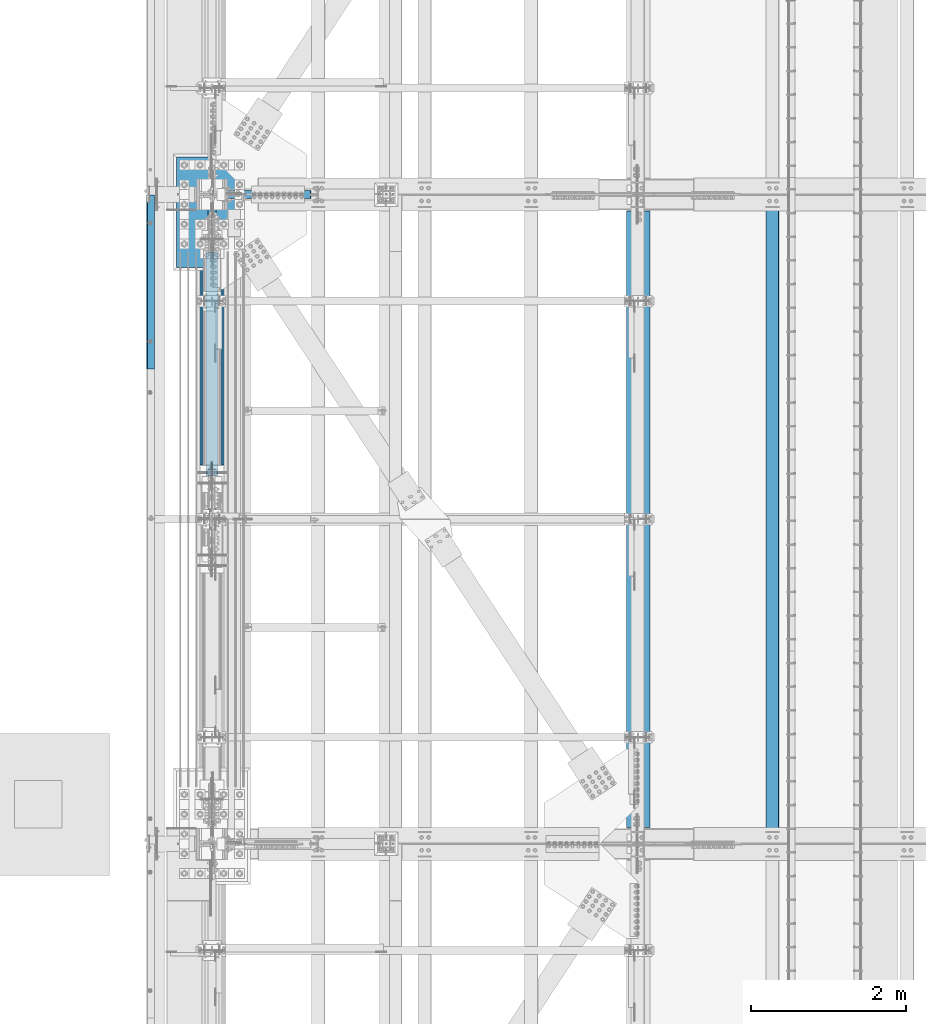
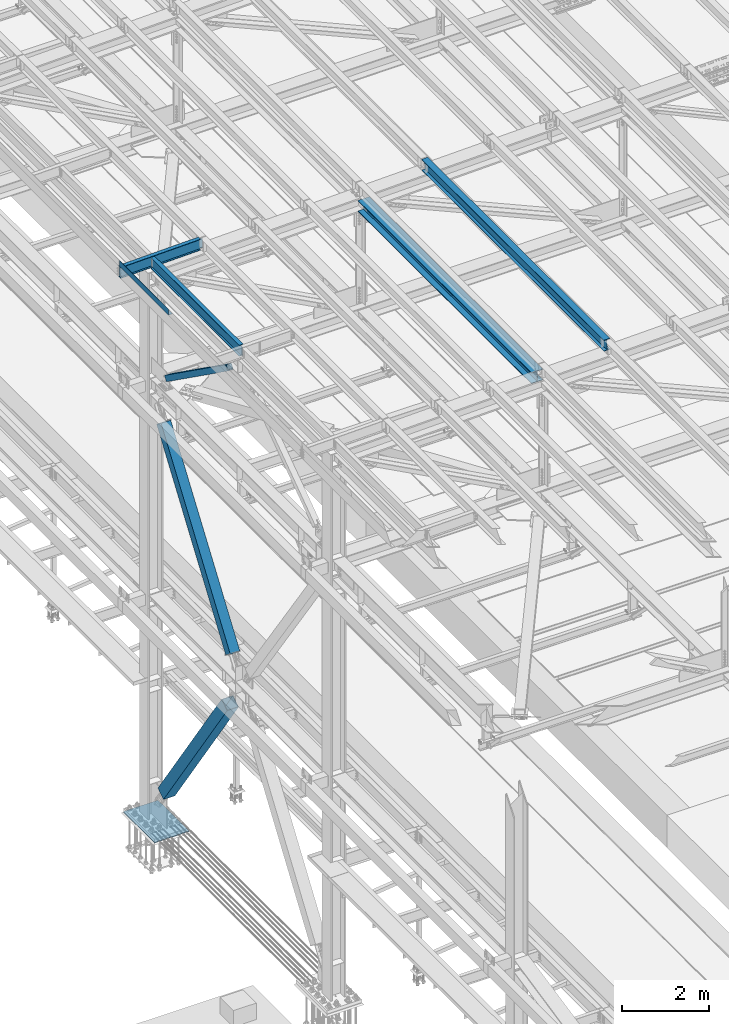
# One storey, part 1817 of 3843: 6 beams, 3 members, 9 elements without a shape of their own.
"""IFC2X3 building model written with IfcOpenShell, lengths in millimetres."""

from ifc_helpers import new_model, si_unit, frame, origin_with_axes, place, context, subcontext, project, spatial, faceted_brep, material, type_object, element, aggregate, save


model = new_model("IFC2X3")

# Units and contexts
model_context = context("Model", 3, precision=1e-05, world=origin_with_axes())
body_context = subcontext(model_context, "Body", "Model", "MODEL_VIEW")
ifc_project = project(units=[si_unit("LENGTHUNIT", "METRE", prefix="MILLI"), si_unit("AREAUNIT", "SQUARE_METRE"), si_unit("VOLUMEUNIT", "CUBIC_METRE"), si_unit("MASSUNIT", "GRAM", prefix="KILO"), si_unit("TIMEUNIT", "SECOND"), si_unit("PLANEANGLEUNIT", "RADIAN"), si_unit("SOLIDANGLEUNIT", "STERADIAN"), si_unit("THERMODYNAMICTEMPERATUREUNIT", "DEGREE_CELSIUS"), si_unit("LUMINOUSINTENSITYUNIT", "LUMEN")], contexts=[model_context])

# Site, building, storey
site_placement = place(None, origin_with_axes())
site = spatial("IfcSite", under=ifc_project, at=site_placement, CompositionType="ELEMENT")
building_placement = place(site_placement, origin_with_axes())
building = spatial("IfcBuilding", under=site, at=building_placement, Name="Undefined", CompositionType="ELEMENT")
storey_placement = place(building_placement, origin_with_axes())
storey = spatial("IfcBuildingStorey", under=building, at=storey_placement, Name="Undefined", CompositionType="ELEMENT", Elevation=0.0)

# Assembly, beam
assembly_1_placement = place(storey_placement, origin_with_axes())
assembly_1 = element("IfcElementAssembly", 1, at=assembly_1_placement, inside=storey, Name="BEAM", AssemblyPlace="NOTDEFINED", PredefinedType="RIGID_FRAME")
ifc_material_1 = material(Name="STEEL/A992")
beam_type_1 = type_object("IfcBeamType", Name="W12X26", PredefinedType="NOTDEFINED")
beam_1_placement = place(assembly_1_placement, frame((43792.6592622999, 50558.6833412205, 45765.7900980518), z_axis=(-0.0211520981284921, -0.000107078999957594, 0.999776263610439), x_axis=(-9.99999682051063e-10, 0.999999994264474, 0.000107103000027897)))
beam_1 = element("IfcBeam", 2, at=beam_1_placement, type_object=beam_type_1, material=ifc_material_1, Name="BEAM", ObjectType="W12X26", context=body_context, shape_type="Brep", body=[
    faceted_brep([(12.6997768804213, 82.5500000002576, -155.574999999757), (12.7008330253957, 82.5499999995081, -146.049999999814), (8343.90088084375, 82.5499999732128, -146.05000001478), (8343.89983598545, 82.549999998897, -155.574999980701), (12.7010127666945, 3.17499999966094, -146.04999999985), (8343.90106058505, 3.17499997337291, -146.050000014817), (12.7322905590408, 3.17500000024302, 146.049999999814), (8343.9323383774, 3.17499997394043, 146.049999984854), (12.7321108177493, 82.5500000000829, 146.049999999857), (8343.9321586361, 82.5499999737876, 146.049999984891), (12.7331307457644, 82.5500000001048, 155.574999999844), (8343.93317856411, 82.5499999738022, 155.574999984885), (12.7335046076623, -82.5499999995736, 155.574999999764), (8343.93355242601, -82.5500000258689, 155.574999984798), (12.7324846796473, -82.5499999995882, 146.049999999763), (8343.93253249799, -82.5500000258835, 146.049999984811), (12.7323049383558, -3.17499999974825, 146.049999999806), (8343.9323527567, -3.17500002604356, 146.049999984854), (12.7010271459949, -3.17500000032305, -146.049999999857), (8343.90107496434, -3.17500002661836, -146.050000014817), (12.7012068873009, -82.550000000163, -146.049999999894), (8343.90125470564, -82.5500000264656, -146.05000001486), (12.7002233139719, -82.5499999994645, -155.574999999291), (8343.90025833794, -82.5500000013853, -155.574999977143)], [[[0, 1, 2, 3]], [[1, 4, 5, 2]], [[4, 6, 7, 5]], [[6, 8, 9, 7]], [[8, 10, 11, 9]], [[10, 12, 13, 11]], [[12, 14, 15, 13]], [[14, 16, 17, 15]], [[16, 18, 19, 17]], [[18, 20, 21, 19]], [[20, 22, 23, 21]], [[22, 0, 3, 23]], [[5, 7, 9, 11, 13, 15, 17, 19, 21, 23, 3, 2]], [[22, 20, 18, 16, 14, 12, 10, 8, 6, 4, 1, 0]]]),
])
aggregate(assembly_1, [beam_1])

assembly_2_placement = place(storey_placement, origin_with_axes())
assembly_2 = element("IfcElementAssembly", 3, at=assembly_2_placement, inside=storey, Name="BEAM", AssemblyPlace="NOTDEFINED", PredefinedType="RIGID_FRAME")
ifc_material_2 = material(Name="STEEL/A36")
beam_type_2 = type_object("IfcBeamType", PredefinedType="NOTDEFINED")
beam_2_placement = place(assembly_2_placement, frame((35839.3101110085, 57791.35, 45717.184316068), z_axis=(0.0, -1.0, 0.0), x_axis=(-0.999776270257024, 0.0, -0.0211520550054595)))
beam_2 = element("IfcBeam", 4, at=beam_2_placement, type_object=beam_type_2, material=ifc_material_2, Name="BENT_PLATE", context=body_context, shape_type="Brep", body=[
    faceted_brep([(-7.27595761418343e-12, -4.77739376947284e-08, 1120.775), (-7.27595761418343e-12, -3.17500000000291, 1117.60000004771), (95.2499999984138, -3.17499999993015, 1117.60000004771), (98.4249999509411, -4.77011781185865e-08, 1120.775), (95.2499999992069, -161.924999997405, 1117.60000004772), (98.4249999517488, -161.924999997391, 1120.775), (-7.27595761418343e-12, -3.17500000000291, -1120.775), (95.2499999984138, -3.17499999993015, -1120.775), (-7.27595761418343e-12, 3.17499999998836, 1120.775), (-7.27595761418343e-12, 3.17499999998836, -1120.775), (101.599999998383, 3.17500000006112, 1120.775), (101.599999998383, 3.17500000006112, -1120.775), (101.599999999198, -161.924999997369, 1120.775), (101.599999999198, -161.924999997369, -1120.775), (95.2499999992069, -161.924999997405, -1120.775)], [[[0, 1, 2, 3]], [[3, 2, 4, 5]], [[6, 7, 2, 1]], [[8, 9, 6, 1, 0]], [[9, 8, 10, 11]], [[11, 10, 12, 13]], [[12, 10, 8, 0, 3, 5]], [[7, 14, 4, 2]], [[7, 6, 9, 11, 13, 14]], [[14, 13, 12, 5, 4]]]),
])
aggregate(assembly_2, [beam_2])

assembly_3_placement = place(storey_placement, origin_with_axes())
assembly_3 = element("IfcElementAssembly", 5, at=assembly_3_placement, inside=storey, Name="BEAM", AssemblyPlace="NOTDEFINED", PredefinedType="RIGID_FRAME")
beam_type_3 = type_object("IfcBeamType", Name="W12X19", PredefinedType="NOTDEFINED")
beam_3_placement = place(assembly_3_placement, frame((35741.6402804658, 58915.3, 45557.9213669187), z_axis=(-0.0249389100004046, 0.0, 0.999688977016348), x_axis=(0.999688977016348, 0.0, 0.0249389100004081)))
beam_3 = element("IfcBeam", 6, at=beam_3_placement, type_object=beam_type_3, material=ifc_material_1, Name="BEAM", ObjectType="W12X19", context=body_context, shape_type="Brep", body=[
    faceted_brep([(2104.3478082233, -3.17500000000291, -144.462500003421), (2104.3478082233, -50.8000000000029, -144.462500003421), (2104.31172906297, -50.8000000000029, -153.987500003444), (2104.31172906297, 50.8000000000029, -153.987500003444), (2104.3478082233, 50.8000000000029, -144.462500003421), (2104.3478082233, 3.17500000000291, -144.462500003421), (2104.3612556739, 3.17500000000291, -140.912335149165), (2104.3612556739, -3.17500000000291, -140.912335149165), (2105.34638772492, 3.17500000000291, -136.055952286675), (2105.34638772492, -3.17500000000291, -136.055952286675), (2108.11498832639, 3.17500000000291, -131.946233272582), (2108.11498832639, -3.17500000000291, -131.946233272582), (2112.24556313414, 3.17500000000291, -129.208845572117), (2112.24556313414, -3.17500000000291, -129.208845572117), (2117.10926957747, 3.17500000000291, -128.260531648179), (2117.10926957747, -3.17500000000291, -128.260531648179), (2186.95876866167, -3.17500000000291, -128.525110259921), (2186.95876866167, 3.17500000000291, -128.525110259921), (4.36557456851006e-11, 3.17500000000291, 144.462499999994), (4.36557456851006e-11, 50.8000000000029, 144.462499999994), (2105.44220941937, 50.8000000000029, 144.462499997368), (2105.44220941937, 3.17500000000291, 144.462499997368), (-3.63797880709171e-11, -50.8000000000029, -153.987499999988), (-3.63797880709171e-11, -50.8000000000029, -144.46249999998), (-3.63797880709171e-11, -3.17500000000291, -144.46249999998), (4.36557456851006e-11, -3.17500000000291, 144.462499999994), (4.36557456851006e-11, -50.8000000000029, 144.462499999994), (3.63797880709171e-11, -50.8000000000029, 153.987499999988), (3.63797880709171e-11, 50.8000000000029, 153.987499999988), (-3.63797880709171e-11, 3.17500000000291, -144.46249999998), (-3.63797880709171e-11, 50.8000000000029, -144.46249999998), (-3.63797880709171e-11, 50.8000000000029, -153.987499999988), (2105.44220941937, -3.17500000000291, 144.462499997368), (2105.44220941937, -50.8000000000029, 144.462499997368), (2105.4782885797, -50.8000000000029, 153.987499997391), (2105.4782885797, 50.8000000000029, 153.987499997391), (2105.43159641651, -3.17500000000291, 141.660637336121), (2105.43159641651, 3.17500000000291, 141.660637336121), (2106.37991034045, -3.17500000000291, 136.7969308928), (2106.37991034045, 3.17500000000291, 136.7969308928), (2109.11729804092, -3.17500000000291, 132.66635608505), (2109.11729804092, 3.17500000000291, 132.66635608505), (2113.227017055, -3.17500000000291, 129.897755483587), (2113.227017055, 3.17500000000291, 129.897755483587), (2118.08339991749, -3.17500000000291, 128.912623432559), (2118.08339991749, 3.17500000000291, 128.912623432559), (2187.93289900266, -3.17500000000291, 128.648044820817), (2187.93289900266, 3.17500000000291, 128.648044820817)], [[[0, 1, 2, 3, 4, 5, 6, 7]], [[7, 6, 8, 9]], [[9, 8, 10, 11]], [[11, 10, 12, 13]], [[13, 12, 14, 15]], [[16, 15, 14, 17]], [[18, 19, 20, 21]], [[22, 23, 24, 25, 26, 27, 28, 19, 18, 29, 30, 31]], [[26, 25, 32, 33]], [[27, 26, 33, 34]], [[28, 27, 34, 35]], [[19, 28, 35, 20]], [[34, 33, 32, 36, 37, 21, 20, 35]], [[38, 39, 37, 36]], [[40, 41, 39, 38]], [[42, 43, 41, 40]], [[44, 45, 43, 42]], [[46, 47, 45, 44]], [[47, 46, 16, 17]], [[12, 10, 8, 6, 5, 29, 18, 21, 37, 39, 41, 43, 45, 47, 17, 14]], [[30, 29, 5, 4]], [[31, 30, 4, 3]], [[22, 31, 3, 2]], [[23, 22, 2, 1]], [[24, 23, 1, 0]], [[46, 44, 42, 40, 38, 36, 32, 25, 24, 0, 7, 9, 11, 13, 15, 16]]]),
])
aggregate(assembly_3, [beam_3])

assembly_4_placement = place(storey_placement, origin_with_axes())
assembly_4 = element("IfcElementAssembly", 7, at=assembly_4_placement, inside=storey, Name="BEAM", AssemblyPlace="NOTDEFINED", PredefinedType="RIGID_FRAME")
beam_4_placement = place(assembly_4_placement, frame((36575.9999999535, 54737.0, 45575.6071293689), z_axis=(0.0, 0.0, 1.0), x_axis=(0.0, 1.0, 0.0)))
beam_4 = element("IfcBeam", 8, at=beam_4_placement, type_object=beam_type_3, material=ifc_material_1, Name="BEAM", ObjectType="W12X19", context=body_context, shape_type="Brep", body=[
    faceted_brep([(4111.62499999991, -3.17500000000291, -144.462500000001), (4111.62499999991, -50.8000000000029, -144.462500000001), (4111.62499999991, -50.8000000000029, -153.987500000003), (4111.62499999991, 50.8000000000029, -153.987500000003), (4111.62499999991, 50.8000000000029, -144.462500000001), (4111.62499999991, 3.17500000000291, -144.462500000001), (4111.62499999991, 3.17500000000291, -141.287499808204), (4111.62499999991, -3.17500000000291, -141.287499808204), (4112.5917299225, 3.17500000000291, -136.427420290158), (4112.5917299225, -3.17500000000291, -136.427420290158), (4115.34474382298, 3.17500000000291, -132.307243822004), (4115.34474382298, -3.17500000000291, -132.307243822004), (4119.46492029114, 3.17500000000291, -129.55422992153), (4119.46492029114, -3.17500000000291, -129.55422992153), (4124.32499980918, 3.17500000000291, -128.587499998939), (4124.32499980918, -3.17500000000291, -128.587499998939), (4162.42499999992, -3.17500000000291, -128.587499998939), (4162.42499999992, 3.17500000000291, -128.587499998939), (4111.62499999991, 50.8000000000029, 144.462500000001), (4111.62499999991, 3.17500000000291, 144.462500000001), (66.6750000000175, 3.17500000000291, 144.462500000001), (66.6750000000175, 50.8000000000029, 144.462500000001), (66.6750000000175, -3.17500000000291, -141.287499808226), (66.6750000000175, 3.17500000000291, -141.287499808226), (66.6750000000175, 3.17500000000291, -144.462500000001), (66.6750000000175, 50.8000000000029, -144.462500000001), (66.6750000000175, 50.8000000000029, -153.987500000003), (66.6750000000175, -50.8000000000029, -153.987500000003), (66.6750000000175, -50.8000000000029, -144.462500000001), (66.6750000000175, -3.17500000000291, -144.462500000001), (65.7082700774336, -3.17500000000291, -136.42742029018), (65.7082700774336, 3.17500000000291, -136.42742029018), (62.9552561769524, -3.17500000000291, -132.307243822026), (62.9552561769524, 3.17500000000291, -132.307243822026), (58.8350797087915, -3.17500000000291, -129.554229921552), (58.8350797087915, 3.17500000000291, -129.554229921552), (53.9750001907523, -3.17500000000291, -128.587499998961), (53.9750001907523, 3.17500000000291, -128.587499998961), (15.8750000000146, -3.17500000000291, -128.587499998961), (15.8750000000146, 3.17500000000291, -128.587499998961), (15.8750000000146, -3.17500000000291, 128.587500001042), (15.8750000000146, 3.17500000000291, 128.587500001042), (15.8750000000146, 3.17500000000291, 115.887500001612), (15.8750000000146, 3.17500000000291, -114.712499998386), (53.9750001907523, -3.17500000000291, 128.587500001042), (53.9750001907523, 3.17500000000291, 128.587500001042), (58.8350797087915, -3.17500000000291, 129.554229923633), (58.8350797087915, 3.17500000000291, 129.554229923633), (62.9552561769524, -3.17500000000291, 132.307243824107), (62.9552561769524, 3.17500000000291, 132.307243824107), (65.7082700774336, -3.17500000000291, 136.427420292261), (65.7082700774336, 3.17500000000291, 136.427420292261), (66.6750000000175, -3.17500000000291, 141.287499810307), (66.6750000000175, 3.17500000000291, 141.287499810307), (66.6750000000175, -50.8000000000029, 153.987500000003), (66.6750000000175, 50.8000000000029, 153.987500000003), (66.6750000000175, -3.17500000000291, 144.462500000001), (66.6750000000175, -50.8000000000029, 144.462500000001), (4111.62499999991, -3.17500000000291, 144.462500000001), (4111.62499999991, -50.8000000000029, 144.462500000001), (4111.62499999991, -50.8000000000029, 153.987500000003), (4111.62499999991, 50.8000000000029, 153.987500000003), (4111.62499999991, -3.17500000000291, 141.287499810329), (4111.62499999991, 3.17500000000291, 141.287499810329), (4112.5917299225, -3.17500000000291, 136.427420292282), (4112.5917299225, 3.17500000000291, 136.427420292282), (4115.34474382298, -3.17500000000291, 132.307243824129), (4115.34474382298, 3.17500000000291, 132.307243824129), (4119.46492029114, -3.17500000000291, 129.554229923655), (4119.46492029114, 3.17500000000291, 129.554229923655), (4124.32499980918, -3.17500000000291, 128.587500001064), (4124.32499980918, 3.17500000000291, 128.587500001064), (4162.42499999992, -3.17500000000291, 128.587500001064), (4162.42499999992, 3.17500000000291, 128.587500001064), (4162.42499999992, 3.17500000000291, -114.712499998423), (4162.42499999992, 3.17500000000291, 115.887500001576)], [[[0, 1, 2, 3, 4, 5, 6, 7]], [[7, 6, 8, 9]], [[9, 8, 10, 11]], [[11, 10, 12, 13]], [[13, 12, 14, 15]], [[16, 15, 14, 17]], [[18, 19, 20, 21]], [[22, 23, 24, 25, 26, 27, 28, 29]], [[30, 31, 23, 22]], [[32, 33, 31, 30]], [[34, 35, 33, 32]], [[36, 37, 35, 34]], [[38, 39, 37, 36]], [[40, 41, 42, 43, 39, 38]], [[44, 45, 41, 40]], [[46, 47, 45, 44]], [[48, 49, 47, 46]], [[50, 51, 49, 48]], [[52, 53, 51, 50]], [[54, 55, 21, 20, 53, 52, 56, 57]], [[58, 59, 57, 56]], [[59, 60, 54, 57]], [[60, 61, 55, 54]], [[61, 18, 21, 55]], [[60, 59, 58, 62, 63, 19, 18, 61]], [[64, 65, 63, 62]], [[66, 67, 65, 64]], [[68, 69, 67, 66]], [[70, 71, 69, 68]], [[72, 73, 71, 70]], [[74, 75, 73, 72, 16, 17]], [[33, 35, 37, 39, 43, 42, 41, 45, 47, 49, 51, 53, 20, 19, 63, 65, 67, 69, 71, 73, 75, 74, 17, 14, 12, 10, 8, 6, 5, 24, 23, 31]], [[5, 4, 25, 24]], [[4, 3, 26, 25]], [[3, 2, 27, 26]], [[2, 1, 28, 27]], [[1, 0, 29, 28]], [[0, 7, 9, 11, 13, 15, 16, 72, 70, 68, 66, 64, 62, 58, 56, 52, 50, 48, 46, 44, 40, 38, 36, 34, 32, 30, 22, 29]]]),
])
aggregate(assembly_4, [beam_4])

# Assembly, member
assembly_5_placement = place(storey_placement, origin_with_axes())
assembly_5 = element("IfcElementAssembly", 9, at=assembly_5_placement, inside=storey, Name="None", AssemblyPlace="NOTDEFINED", PredefinedType="RIGID_FRAME")
member_type_1 = type_object("IfcMemberType", Name="HSS10X10X1/4", PredefinedType="NOTDEFINED")
member_1_placement = place(assembly_5_placement, frame((36576.0, 55186.1621232313, 36895.0047550831), z_axis=(1.0, 0.0, 0.0), x_axis=(0.0, 0.572746499261054, 0.819732546373637)))
member_1 = element("IfcMember", 10, at=member_1_placement, type_object=member_type_1, material=ifc_material_1, Name="None", ObjectType="HSS10X10X1/4", context=body_context, shape_type="Brep", body=[
    faceted_brep([(2.00088834390044e-10, 120.650000000089, -120.649999999994), (-2.03726813197136e-10, -120.650000000081, -120.649999999994), (5518.15000014856, -120.650000002668, -120.650000000001), (5518.15000014866, 120.649999998226, -120.650000000001), (-2.03726813197136e-10, -120.650000000081, 120.649999999994), (5518.15000014856, -120.650000002668, 120.650000000001), (2.00088834390044e-10, 120.650000000089, 120.649999999994), (5518.15000014866, 120.649999998226, 120.650000000001), (2.16459739021957e-10, 127.000000000087, -127.0), (2.16459739021957e-10, 127.000000000087, 127.0), (5518.15000014868, 126.999999998254, 127.0), (5518.15000014868, 126.999999998254, -127.0), (-2.14640749618411e-10, -127.00000000008, 127.0), (5518.15000014856, -127.000000002688, 127.0), (-2.14640749618411e-10, -127.00000000008, -127.0), (5518.15000014856, -127.000000002688, -127.0)], [[[0, 1, 2, 3]], [[1, 4, 5, 2]], [[4, 6, 7, 5]], [[6, 0, 3, 7]], [[8, 9, 10, 11]], [[9, 12, 13, 10]], [[12, 14, 15, 13]], [[14, 8, 11, 15]], [[13, 15, 11, 10], [5, 7, 3, 2]], [[14, 12, 9, 8], [6, 4, 1, 0]]]),
])
aggregate(assembly_5, [member_1])

assembly_6_placement = place(storey_placement, origin_with_axes())
assembly_6 = element("IfcElementAssembly", 11, at=assembly_6_placement, inside=storey, Name="None", AssemblyPlace="NOTDEFINED", PredefinedType="RIGID_FRAME")
member_type_2 = type_object("IfcMemberType", Name="HSS12X12X5/16", PredefinedType="NOTDEFINED")
member_2_placement = place(assembly_6_placement, frame((36576.0000061035, 58220.1337747341, 31175.6677921717), z_axis=(-1.0, 0.0, 0.0), x_axis=(0.0, -0.565762265008601, 0.824568408012542)))
member_2 = element("IfcMember", 12, at=member_2_placement, type_object=member_type_2, material=ifc_material_1, Name="None", ObjectType="HSS12X12X5/16", context=body_context, shape_type="Brep", body=[
    faceted_brep([(-2.61934474110603e-10, 144.462500000002, -144.462500000001), (2.61934474110603e-10, -144.462499999993, -144.462500000001), (5149.85050132098, -144.462500004011, -144.462500000001), (5149.85050132096, 144.462499995163, -144.462500000001), (2.61934474110603e-10, -144.462499999993, 144.462500000001), (5149.85050132098, -144.462500004011, 144.462500000001), (-2.61934474110603e-10, 144.462500000002, 144.462500000001), (5149.85050132096, 144.462499995163, 144.462500000001), (-2.7648638933897e-10, 152.400000000002, -152.400000000001), (-2.7648638933897e-10, 152.400000000002, 152.400000000001), (5149.85050132096, 152.399999995148, 152.400000000001), (5149.85050132096, 152.399999995148, -152.400000000001), (2.83762346953154e-10, -152.399999999993, 152.400000000001), (5149.85050132098, -152.400000003981, 152.400000000001), (2.83762346953154e-10, -152.399999999993, -152.400000000001), (5149.85050132098, -152.400000003981, -152.400000000001)], [[[0, 1, 2, 3]], [[1, 4, 5, 2]], [[4, 6, 7, 5]], [[6, 0, 3, 7]], [[8, 9, 10, 11]], [[9, 12, 13, 10]], [[12, 14, 15, 13]], [[14, 8, 11, 15]], [[13, 15, 11, 10], [5, 7, 3, 2]], [[14, 12, 9, 8], [6, 4, 1, 0]]]),
])
aggregate(assembly_6, [member_2])

assembly_7_placement = place(storey_placement, origin_with_axes())
assembly_7 = element("IfcElementAssembly", 13, at=assembly_7_placement, inside=storey, AssemblyPlace="NOTDEFINED", PredefinedType="RIGID_FRAME")
ifc_material_3 = material()
member_type_3 = type_object("IfcMemberType", Name="HSS6X6X3/8", PredefinedType="NOTDEFINED")
member_3_placement = place(assembly_7_placement, frame((36576.0000000002, 54737.0000012212, 45210.4124983399), z_axis=(1.0, 0.0, 0.0), x_axis=(0.0, 0.814318393718894, -0.580418429799641)))
member_3 = element("IfcMember", 14, at=member_3_placement, type_object=member_type_3, material=ifc_material_3, ObjectType="HSS6X6X3/8", context=body_context, shape_type="Brep", body=[
    faceted_brep([(4171.65947153775, -76.2000000072003, 4.76249999999709), (4171.65947153775, -66.6750000071625, 4.76249999999709), (4071.64697153183, -66.6750000070024, 4.76249999999709), (4071.64697153182, -76.2000000070402, 4.76249999999709), (4068.60942178741, -66.6750000070024, 5.36670621069061), (4068.60942178738, -76.2000000070402, 5.36670621069061), (4066.03431145611, -66.6750000070024, 7.08733992432826), (4066.03431145609, -76.2000000070257, 7.08733992432826), (4064.31367774246, -66.6750000070024, 9.66245025560056), (4064.31367774244, -76.2000000070257, 9.66245025560056), (4063.70947153176, -66.6750000070024, 12.6999999999971), (4063.70947153174, -76.2000000070257, 12.6999999999971), (4064.31367774246, -66.6750000070024, 15.7375497443936), (4064.31367774244, -76.2000000070257, 15.7375497443936), (4066.03431145611, -66.6750000070024, 18.3126600756659), (4066.03431145609, -76.2000000070257, 18.3126600756659), (4068.60942178741, -66.6750000070024, 20.0332937893036), (4068.60942178738, -76.2000000070402, 20.0332937893036), (4071.64697153183, -66.6750000070024, 20.6374999999971), (4071.64697153182, -76.2000000070402, 20.6374999999971), (4171.65947153775, -76.2000000072003, 20.6374999999971), (4171.65947153775, -66.6750000071625, 20.6374999999971), (4171.65947153774, 66.674999993309, 4.76249999999709), (4171.65947153774, 76.1999999933469, 4.76249999999709), (4071.64697153206, 76.1999999935069, 4.76249999999709), (4071.64697153206, 66.6749999934837, 4.76249999999709), (4068.60942178765, 76.1999999935215, 5.36670621069061), (4068.60942178763, 66.6749999934691, 5.36670621069061), (4066.03431145635, 76.1999999935215, 7.08733992432826), (4066.03431145632, 66.6749999934982, 7.08733992432826), (4064.31367774269, 76.1999999935215, 9.66245025560056), (4064.31367774266, 66.6749999934982, 9.66245025560056), (4063.70947153199, 76.1999999935215, 12.6999999999971), (4063.70947153198, 66.6749999934837, 12.6999999999971), (4064.31367774269, 76.1999999935215, 15.7375497443936), (4064.31367774266, 66.6749999934982, 15.7375497443936), (4066.03431145635, 76.1999999935215, 18.3126600756659), (4066.03431145632, 66.6749999934982, 18.3126600756659), (4068.60942178765, 76.1999999935215, 20.0332937893036), (4068.60942178763, 66.6749999934691, 20.0332937893036), (4071.64697153206, 76.1999999935069, 20.6374999999971), (4071.64697153206, 66.6749999934837, 20.6374999999971), (4171.65947153774, 66.674999993309, 20.6374999999971), (4171.65947153774, 76.1999999933469, 20.6374999999971), (735.10236333542, -66.6750000014727, 66.6750000000029), (735.102363335423, 66.6749999989988, 66.6750000000029), (4171.65947153774, 66.674999993309, 66.6750000000029), (4171.65947153775, -66.6750000071625, 66.6750000000029), (840.727523416841, -66.6750000016473, 5.61266007569066), (838.152413085547, -66.6750000016473, 7.33329378932831), (835.114863341114, -66.6750000016327, 7.93750000002183), (735.10236333542, -66.6750000014727, 7.93750000002183), (4171.65947153775, -66.6750000071625, -66.6750000000029), (735.10236333542, -66.6750000014727, -66.6750000000029), (735.10236333542, -66.6750000014727, -7.93749999997817), (835.114863341114, -66.6750000016327, -7.93749999997817), (838.152413085547, -66.6750000016473, -7.33329378928465), (840.727523416841, -66.6750000016473, -5.612660075647), (842.4481571305, -66.6750000016473, -3.0375497443747), (843.052363341201, -66.6750000016473, 2.18278728425503e-11), (842.4481571305, -66.6750000016473, 3.03754974441836), (735.102363335423, 66.6749999989988, -66.6750000000029), (4171.65947153774, 66.674999993309, -66.6750000000029), (735.102363335423, 66.6749999989988, 7.93750000002183), (735.102363335423, 76.1999999990512, 7.93750000002183), (835.114863341361, 76.1999999988911, 7.93750000002183), (835.11486334134, 66.6749999988533, 7.93750000002183), (838.152413085787, 76.1999999988766, 7.33329378932831), (838.152413085765, 66.6749999988388, 7.33329378932831), (840.727523417074, 76.1999999988766, 5.61266007569066), (840.727523417067, 66.6749999988533, 5.61266007569066), (842.448157130733, 76.1999999988766, 3.03754974441836), (842.448157130733, 66.6749999988388, 3.03754974441836), (843.052363341441, 76.1999999988766, 2.18278728425503e-11), (843.052363341434, 66.6749999988388, 2.18278728425503e-11), (842.448157130733, 76.1999999988766, -3.0375497443747), (842.448157130733, 66.6749999988388, -3.0375497443747), (840.727523417074, 76.1999999988766, -5.612660075647), (840.727523417067, 66.6749999988533, -5.612660075647), (838.152413085787, 76.1999999988766, -7.33329378928465), (838.152413085765, 66.6749999988388, -7.33329378928465), (835.114863341361, 76.1999999988911, -7.93749999997817), (835.11486334134, 66.6749999988533, -7.93749999997817), (735.102363335423, 76.1999999990512, -7.93749999997817), (735.102363335423, 66.6749999989988, -7.93749999997817), (735.102363335423, 76.1999999990512, -76.1999999999971), (735.102363335427, -76.2000000014959, -76.1999999999971), (735.102363335427, -76.2000000014959, -7.93749999997817), (835.114863341099, -76.2000000016706, -7.93749999997817), (838.152413085525, -76.2000000016706, -7.33329378928465), (840.727523416834, -76.2000000016706, -5.612660075647), (842.448157130493, -76.2000000016851, -3.0375497443747), (843.052363341194, -76.2000000016706, 2.18278728425503e-11), (842.448157130493, -76.2000000016851, 3.03754974441836), (840.727523416834, -76.2000000016706, 5.61266007569066), (838.152413085525, -76.2000000016706, 7.33329378932831), (835.114863341099, -76.2000000016706, 7.93750000002183), (735.102363335427, -76.2000000014959, 7.93750000002183), (735.102363335427, -76.2000000014959, 76.1999999999971), (735.102363335423, 76.1999999990512, 76.1999999999971), (4171.65947153775, -76.2000000072003, 76.1999999999971), (4171.65947153774, 76.1999999933469, 76.1999999999971), (4171.65947153774, 76.1999999933469, -76.1999999999971), (4171.65947153775, -76.2000000072003, -76.1999999999971)], [[[0, 1, 2, 3]], [[3, 2, 4, 5]], [[5, 4, 6, 7]], [[7, 6, 8, 9]], [[9, 8, 10, 11]], [[11, 10, 12, 13]], [[13, 12, 14, 15]], [[15, 14, 16, 17]], [[17, 16, 18, 19]], [[20, 19, 18, 21]], [[22, 23, 24, 25]], [[25, 24, 26, 27]], [[27, 26, 28, 29]], [[29, 28, 30, 31]], [[31, 30, 32, 33]], [[33, 32, 34, 35]], [[35, 34, 36, 37]], [[37, 36, 38, 39]], [[39, 38, 40, 41]], [[42, 41, 40, 43]], [[44, 45, 46, 47]], [[48, 49, 50, 51, 44, 47, 21, 18, 16, 14, 12, 10, 8, 6, 4, 2, 1, 52, 53, 54, 55, 56, 57, 58, 59, 60]], [[61, 53, 52, 62]], [[63, 64, 65, 66]], [[66, 65, 67, 68]], [[68, 67, 69, 70]], [[70, 69, 71, 72]], [[72, 71, 73, 74]], [[74, 73, 75, 76]], [[76, 75, 77, 78]], [[78, 77, 79, 80]], [[80, 79, 81, 82]], [[82, 81, 83, 84]], [[53, 61, 84, 83, 85, 86, 87, 54]], [[88, 55, 54, 87]], [[89, 56, 55, 88]], [[90, 57, 56, 89]], [[91, 58, 57, 90]], [[92, 59, 58, 91]], [[93, 60, 59, 92]], [[94, 48, 60, 93]], [[95, 49, 48, 94]], [[96, 50, 49, 95]], [[97, 51, 50, 96]], [[98, 99, 64, 63, 45, 44, 51, 97]], [[99, 98, 100, 101]], [[47, 46, 42, 43, 101, 100, 20, 21]], [[69, 67, 65, 64, 99, 101, 43, 40, 38, 36, 34, 32, 30, 28, 26, 24, 23, 102, 85, 83, 81, 79, 77, 75, 73, 71]], [[86, 85, 102, 103]], [[90, 89, 88, 87, 86, 103, 0, 3, 5, 7, 9, 11, 13, 15, 17, 19, 20, 100, 98, 97, 96, 95, 94, 93, 92, 91]], [[103, 102, 23, 22, 62, 52, 1, 0]], [[78, 80, 82, 84, 61, 62, 22, 25, 27, 29, 31, 33, 35, 37, 39, 41, 42, 46, 45, 63, 66, 68, 70, 72, 74, 76]]]),
])
aggregate(assembly_7, [member_3])

# Assembly, beam
assembly_8_placement = place(storey_placement, origin_with_axes())
assembly_8 = element("IfcElementAssembly", 15, at=assembly_8_placement, inside=storey, Name="BEAM", AssemblyPlace="NOTDEFINED", PredefinedType="RIGID_FRAME")
beam_type_4 = type_object("IfcBeamType", Name="W12X65", PredefinedType="NOTDEFINED")
beam_5_placement = place(assembly_8_placement, frame((42062.4, 50558.7, 45368.1453900545), z_axis=(0.0, -7.77469999957245e-05, 0.999999996977702), x_axis=(0.0, 0.999999996977702, 7.77469999981291e-05)))
beam_5 = element("IfcBeam", 16, at=beam_5_placement, type_object=beam_type_4, material=ifc_material_1, Name="BEAM", ObjectType="W12X65", context=body_context, shape_type="Brep", body=[
    faceted_brep([(212.712937886943, 152.400000000001, -153.987499999443), (212.714181470947, 152.400000000001, -138.112499999472), (8143.86420577109, 152.400000000001, -138.112499991308), (8143.86296218709, 152.400000000001, -153.987499991279), (212.714181470947, 4.76249999999709, -138.112499999472), (8143.86420577109, 4.76249999999709, -138.112499991308), (212.735819832611, 4.76249999999709, 138.112499999923), (8143.88584413275, 4.76249999999709, 138.112500008086), (212.735819832611, 152.400000000001, 138.112499999923), (8143.88584413275, 152.400000000001, 138.112500008086), (212.737063416615, 152.400000000001, 153.987499999886), (8143.88708771676, 152.400000000001, 153.987500008043), (212.737063416615, -152.400000000001, 153.987499999886), (8143.88708771676, -152.400000000001, 153.987500008043), (212.735819832611, -152.400000000001, 138.112499999923), (8143.88584413275, -152.400000000001, 138.112500008086), (212.735819832611, -4.76249999999709, 138.112499999923), (8143.88584413275, -4.76249999999709, 138.112500008086), (212.714181470947, -4.76249999999709, -138.112499999472), (8143.86420577109, -4.76249999999709, -138.112499991308), (212.714181470947, -152.400000000001, -138.112499999472), (8143.86420577109, -152.400000000001, -138.112499991308), (212.712937886943, -152.400000000001, -153.987499999443), (8143.86296218709, -152.400000000001, -153.987499991279)], [[[0, 1, 2, 3]], [[1, 4, 5, 2]], [[4, 6, 7, 5]], [[6, 8, 9, 7]], [[8, 10, 11, 9]], [[10, 12, 13, 11]], [[12, 14, 15, 13]], [[14, 16, 17, 15]], [[16, 18, 19, 17]], [[18, 20, 21, 19]], [[20, 22, 23, 21]], [[22, 0, 3, 23]], [[5, 7, 9, 11, 13, 15, 17, 19, 21, 23, 3, 2]], [[22, 20, 18, 16, 14, 12, 10, 8, 6, 4, 1, 0]]]),
])
aggregate(assembly_8, [beam_5])

assembly_9_placement = place(storey_placement, origin_with_axes())
assembly_9 = element("IfcElementAssembly", 17, at=assembly_9_placement, inside=storey, Name="TEMPLATE", AssemblyPlace="NOTDEFINED", PredefinedType="RIGID_FRAME")
ifc_material_4 = material(Name="STEEL/A572-50")
beam_type_5 = type_object("IfcBeamType", PredefinedType="NOTDEFINED")
beam_6_placement = place(assembly_9_placement, frame((37033.1990112305, 58686.7, 30067.25), z_axis=(0.0, -1.0, 0.0), x_axis=(-1.0, 0.0, 0.0)))
beam_6 = element("IfcBeam", 18, at=beam_6_placement, type_object=beam_type_5, material=ifc_material_4, Name="TEMPLATE", context=body_context, shape_type="Brep", body=[
    faceted_brep([(0.0, 6.34999999999854, -711.199999999997), (0.0, 6.34999999999854, 711.200012207031), (914.39802246094, 6.34999999999854, 711.199999999997), (914.39802246094, 6.34999999999854, -711.199999999997), (0.0, -6.34999999999854, 711.200012207031), (914.39802246094, -6.34999999999854, 711.199999999997), (0.0, -6.34999999999854, -711.199999999997), (914.39802246094, -6.34999999999854, -711.199999999997)], [[[0, 1, 2, 3]], [[1, 4, 5, 2]], [[4, 6, 7, 5]], [[6, 0, 3, 7]], [[5, 7, 3, 2]], [[6, 4, 1, 0]]]),
])
aggregate(assembly_9, [beam_6])

save(model, "model.ifc")
